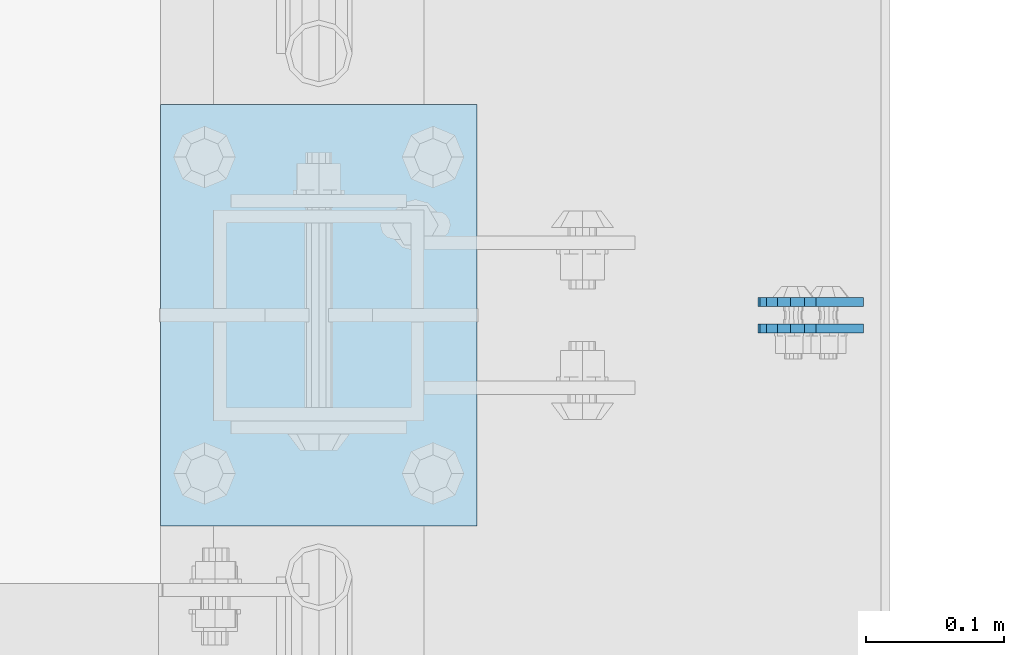
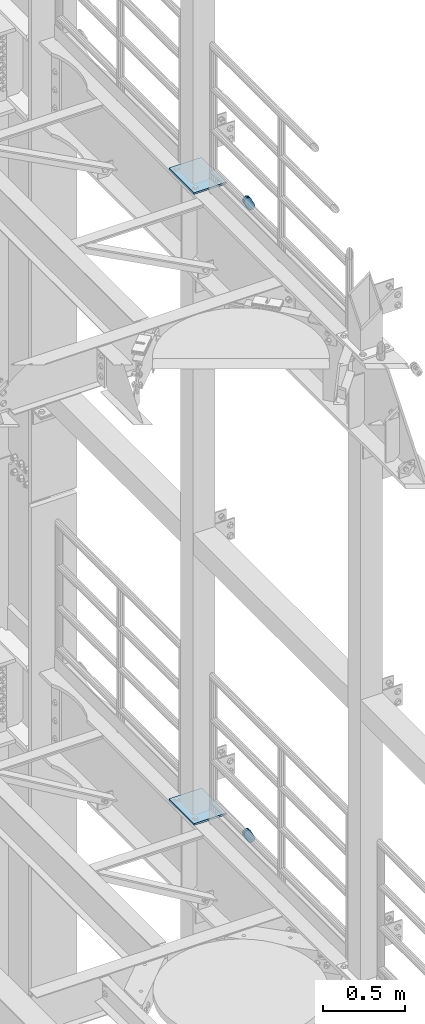
# One storey, part 1681 of 1876: 6 plates, 6 elements without a shape of their own.
"""IFC2X3 building model written with IfcOpenShell, lengths in millimetres."""

from ifc_helpers import new_model, si_unit, frame, origin_with_axes, place, context, subcontext, project, spatial, faceted_brep, material, type_object, element, aggregate, save


model = new_model("IFC2X3")

# Units and contexts
model_context = context("Model", 3, precision=1e-05, world=origin_with_axes())
body_context = subcontext(model_context, "Body", "Model", "MODEL_VIEW")
ifc_project = project(units=[si_unit("LENGTHUNIT", "METRE", prefix="MILLI"), si_unit("AREAUNIT", "SQUARE_METRE"), si_unit("VOLUMEUNIT", "CUBIC_METRE"), si_unit("MASSUNIT", "GRAM", prefix="KILO"), si_unit("TIMEUNIT", "SECOND"), si_unit("PLANEANGLEUNIT", "RADIAN"), si_unit("SOLIDANGLEUNIT", "STERADIAN"), si_unit("THERMODYNAMICTEMPERATUREUNIT", "DEGREE_CELSIUS"), si_unit("LUMINOUSINTENSITYUNIT", "LUMEN")], contexts=[model_context])

# Site, building, storey
site_placement = place(None, origin_with_axes())
site = spatial("IfcSite", under=ifc_project, at=site_placement, CompositionType="ELEMENT")
building_placement = place(site_placement, origin_with_axes())
building = spatial("IfcBuilding", under=site, at=building_placement, Name="Undefined", CompositionType="ELEMENT")
storey_placement = place(building_placement, origin_with_axes())
storey = spatial("IfcBuildingStorey", under=building, at=storey_placement, Name="Undefined", CompositionType="ELEMENT", Elevation=0.0)

# Assembly, plate
assembly_1_placement = place(storey_placement, origin_with_axes())
assembly_1 = element("IfcElementAssembly", 1, at=assembly_1_placement, inside=storey, Name="PLATE", AssemblyPlace="NOTDEFINED", PredefinedType="RIGID_FRAME")
ifc_material = material(Name="STEEL/A36")
plate_type_1 = type_object("IfcPlateType", PredefinedType="NOTDEFINED")
plate_1_placement = place(assembly_1_placement, frame((7974.16265106708, 5578.47500307524, 17725.1776774809), z_axis=(-0.894427191199917, 1.49999996210681e-08, -0.447213595099955), x_axis=(0.447213595099955, -6.99999707257281e-09, -0.894427191199917)))
plate_1 = element("IfcPlate", 2, at=plate_1_placement, type_object=plate_type_1, material=ifc_material, Name="PLATE", context=body_context, shape_type="Brep", body=[
    faceted_brep([(-8.59611645864788e-07, -3.17499999999654, 25.3999987589127), (1.93345873884391, -3.17499999999382, 35.1201580589886), (1.93345873884391, 3.17500000000564, 35.1201580589886), (-8.59611645864788e-07, 3.17500000000382, 25.3999987589132), (7.43948648259902, -3.17499999999109, 43.3605112870105), (7.43948648259902, 3.17500000000928, 43.3605112870105), (15.6798395242777, -3.17499999998654, 48.8665393096448), (15.6798395242777, 3.17500000001382, 48.8665393096448), (25.3999987589095, -3.17499999998199, 50.7999992370592), (25.3999987589095, 3.17500000001837, 50.7999992370592), (82.196130752618, -3.17499999998381, 50.7999992370605), (82.196130752618, 3.17500000001655, 50.7999992370642), (91.9162897887145, -3.17499999997926, 48.8665393918873), (91.9162897887145, 3.1750000000211, 48.8665393918909), (100.156642725027, -3.17499999997472, 43.3605115909359), (100.156642725027, 3.17500000002565, 43.3605115909395), (105.662670525982, -3.17499999997108, 35.1201586546285), (105.662670525986, 3.17500000002929, 35.1201586546358), (107.596130371159, -3.17499999996744, 25.3999996185757), (107.596130371159, 3.17500000003292, 25.3999996185794), (105.662670525981, -3.17499999996471, 15.6798405824902), (105.662670525981, 3.17500000003565, 15.6798405824939), (100.156642725024, -3.17499999996471, 7.43948764618654), (100.156642725025, 3.17500000003565, 7.43948764619017), (91.9162897887127, -3.17499999996562, 1.93345984522784), (91.9162897887127, 3.17500000003474, 1.93345984523148), (82.196130752618, -3.17499999996835, 4.54747350886464e-11), (82.196130752618, 3.1750000000311, 4.91127138957381e-11), (25.399998758905, -3.17499999999018, -8.64019966684282e-12), (25.399998758905, 3.17500000001019, -8.64019966684282e-12), (15.679839921364, -3.17499999999382, 1.9334597629304), (15.679839921364, 3.17500000000655, 1.9334597629304), (7.43948709043525, -3.17499999999654, 7.43948734220839), (7.43948709043525, 3.17500000000382, 7.43948734220885), (1.93345923228208, -3.17499999999654, 15.6798399868012), (1.93345923228208, 3.17500000000291, 15.6798399868012)], [[[0, 1, 2, 3]], [[1, 4, 5, 2]], [[4, 6, 7, 5]], [[6, 8, 9, 7]], [[8, 10, 11, 9]], [[10, 12, 13, 11]], [[12, 14, 15, 13]], [[14, 16, 17, 15]], [[16, 18, 19, 17]], [[18, 20, 21, 19]], [[20, 22, 23, 21]], [[22, 24, 25, 23]], [[24, 26, 27, 25]], [[26, 28, 29, 27]], [[28, 30, 31, 29]], [[30, 32, 33, 31]], [[32, 34, 35, 33]], [[34, 0, 3, 35]], [[5, 7, 9, 11, 13, 15, 17, 19, 21, 23, 25, 27, 29, 31, 33, 35, 3, 2]], [[34, 32, 30, 28, 26, 24, 22, 20, 18, 16, 14, 12, 10, 8, 6, 4, 1, 0]]]),
])
aggregate(assembly_1, [plate_1])

assembly_2_placement = place(storey_placement, origin_with_axes())
assembly_2 = element("IfcElementAssembly", 3, at=assembly_2_placement, inside=storey, Name="PLATE", AssemblyPlace="NOTDEFINED", PredefinedType="RIGID_FRAME")
plate_2_placement = place(assembly_2_placement, frame((7974.16265166367, 5597.53619937992, 17725.1776774809), z_axis=(-0.894427191199917, 1.49999996210681e-08, -0.447213595099955), x_axis=(0.447213595099955, -6.99999707257281e-09, -0.894427191199917)))
plate_2 = element("IfcPlate", 4, at=plate_2_placement, type_object=plate_type_1, material=ifc_material, Name="PLATE", context=body_context, shape_type="Brep", body=[
    faceted_brep([(-8.59611645864788e-07, -3.17499999999654, 25.3999987589127), (1.93345873884391, -3.17499999999382, 35.1201580589886), (1.93345873884391, 3.17500000000564, 35.1201580589886), (-8.59611645864788e-07, 3.17500000000382, 25.3999987589132), (7.43948648259902, -3.17499999999109, 43.3605112870105), (7.43948648259902, 3.17500000000928, 43.3605112870105), (15.6798395242777, -3.17499999998654, 48.8665393096448), (15.6798395242777, 3.17500000001382, 48.8665393096448), (25.3999987589095, -3.17499999998199, 50.7999992370592), (25.3999987589095, 3.17500000001837, 50.7999992370592), (82.196130752618, -3.17499999998381, 50.7999992370605), (82.196130752618, 3.17500000001655, 50.7999992370642), (91.9162897887145, -3.17499999997926, 48.8665393918873), (91.9162897887145, 3.1750000000211, 48.8665393918909), (100.156642725027, -3.17499999997472, 43.3605115909359), (100.156642725027, 3.17500000002565, 43.3605115909395), (105.662670525982, -3.17499999997108, 35.1201586546285), (105.662670525986, 3.17500000002929, 35.1201586546358), (107.596130371159, -3.17499999996744, 25.3999996185757), (107.596130371159, 3.17500000003292, 25.3999996185794), (105.662670525981, -3.17499999996471, 15.6798405824902), (105.662670525981, 3.17500000003565, 15.6798405824939), (100.156642725024, -3.17499999996471, 7.43948764618654), (100.156642725025, 3.17500000003565, 7.43948764619017), (91.9162897887127, -3.17499999996562, 1.93345984522784), (91.9162897887127, 3.17500000003474, 1.93345984523148), (82.196130752618, -3.17499999996835, 4.54747350886464e-11), (82.196130752618, 3.1750000000311, 4.91127138957381e-11), (25.399998758905, -3.17499999999018, -8.64019966684282e-12), (25.399998758905, 3.17500000001019, -8.64019966684282e-12), (15.679839921364, -3.17499999999382, 1.9334597629304), (15.679839921364, 3.17500000000655, 1.9334597629304), (7.43948709043525, -3.17499999999654, 7.43948734220839), (7.43948709043525, 3.17500000000382, 7.43948734220885), (1.93345923228208, -3.17499999999654, 15.6798399868012), (1.93345923228208, 3.17500000000291, 15.6798399868012)], [[[0, 1, 2, 3]], [[1, 4, 5, 2]], [[4, 6, 7, 5]], [[6, 8, 9, 7]], [[8, 10, 11, 9]], [[10, 12, 13, 11]], [[12, 14, 15, 13]], [[14, 16, 17, 15]], [[16, 18, 19, 17]], [[18, 20, 21, 19]], [[20, 22, 23, 21]], [[22, 24, 25, 23]], [[24, 26, 27, 25]], [[26, 28, 29, 27]], [[28, 30, 31, 29]], [[30, 32, 33, 31]], [[32, 34, 35, 33]], [[34, 0, 3, 35]], [[5, 7, 9, 11, 13, 15, 17, 19, 21, 23, 25, 27, 29, 31, 33, 35, 3, 2]], [[34, 32, 30, 28, 26, 24, 22, 20, 18, 16, 14, 12, 10, 8, 6, 4, 1, 0]]]),
])
aggregate(assembly_2, [plate_2])

assembly_3_placement = place(storey_placement, origin_with_axes())
assembly_3 = element("IfcElementAssembly", 5, at=assembly_3_placement, inside=storey, Name="PLATE", AssemblyPlace="NOTDEFINED", PredefinedType="RIGID_FRAME")
plate_3_placement = place(assembly_3_placement, frame((7974.16265106708, 5578.47500307524, 13038.8776774809), z_axis=(-0.894427191199917, 1.49999996210681e-08, -0.447213595099955), x_axis=(0.447213595099955, -6.99999707257281e-09, -0.894427191199917)))
plate_3 = element("IfcPlate", 6, at=plate_3_placement, type_object=plate_type_1, material=ifc_material, Name="PLATE", context=body_context, shape_type="Brep", body=[
    faceted_brep([(-8.59611645864788e-07, -3.17499999999654, 25.3999987589127), (1.93345873884391, -3.17499999999382, 35.1201580589886), (1.93345873884391, 3.17500000000564, 35.1201580589886), (-8.59611645864788e-07, 3.17500000000382, 25.3999987589132), (7.43948648259902, -3.17499999999109, 43.3605112870105), (7.43948648259902, 3.17500000000928, 43.3605112870105), (15.6798395242777, -3.17499999998654, 48.8665393096448), (15.6798395242777, 3.17500000001382, 48.8665393096448), (25.3999987589095, -3.17499999998199, 50.7999992370592), (25.3999987589095, 3.17500000001837, 50.7999992370592), (82.196130752618, -3.17499999998381, 50.7999992370605), (82.196130752618, 3.17500000001655, 50.7999992370642), (91.9162897887145, -3.17499999997926, 48.8665393918873), (91.9162897887145, 3.1750000000211, 48.8665393918909), (100.156642725027, -3.17499999997472, 43.3605115909359), (100.156642725027, 3.17500000002565, 43.3605115909395), (105.662670525982, -3.17499999997108, 35.1201586546285), (105.662670525986, 3.17500000002929, 35.1201586546358), (107.596130371159, -3.17499999996744, 25.3999996185757), (107.596130371159, 3.17500000003292, 25.3999996185794), (105.662670525981, -3.17499999996471, 15.6798405824902), (105.662670525981, 3.17500000003565, 15.6798405824939), (100.156642725024, -3.17499999996471, 7.43948764618654), (100.156642725025, 3.17500000003565, 7.43948764619017), (91.9162897887127, -3.17499999996562, 1.93345984522784), (91.9162897887127, 3.17500000003474, 1.93345984523148), (82.196130752618, -3.17499999996835, 4.54747350886464e-11), (82.196130752618, 3.1750000000311, 4.91127138957381e-11), (25.399998758905, -3.17499999999018, -8.64019966684282e-12), (25.399998758905, 3.17500000001019, -8.64019966684282e-12), (15.679839921364, -3.17499999999382, 1.9334597629304), (15.679839921364, 3.17500000000655, 1.9334597629304), (7.43948709043525, -3.17499999999654, 7.43948734220839), (7.43948709043525, 3.17500000000382, 7.43948734220885), (1.93345923228208, -3.17499999999654, 15.6798399868012), (1.93345923228208, 3.17500000000291, 15.6798399868012)], [[[0, 1, 2, 3]], [[1, 4, 5, 2]], [[4, 6, 7, 5]], [[6, 8, 9, 7]], [[8, 10, 11, 9]], [[10, 12, 13, 11]], [[12, 14, 15, 13]], [[14, 16, 17, 15]], [[16, 18, 19, 17]], [[18, 20, 21, 19]], [[20, 22, 23, 21]], [[22, 24, 25, 23]], [[24, 26, 27, 25]], [[26, 28, 29, 27]], [[28, 30, 31, 29]], [[30, 32, 33, 31]], [[32, 34, 35, 33]], [[34, 0, 3, 35]], [[5, 7, 9, 11, 13, 15, 17, 19, 21, 23, 25, 27, 29, 31, 33, 35, 3, 2]], [[34, 32, 30, 28, 26, 24, 22, 20, 18, 16, 14, 12, 10, 8, 6, 4, 1, 0]]]),
])
aggregate(assembly_3, [plate_3])

assembly_4_placement = place(storey_placement, origin_with_axes())
assembly_4 = element("IfcElementAssembly", 7, at=assembly_4_placement, inside=storey, Name="PLATE", AssemblyPlace="NOTDEFINED", PredefinedType="RIGID_FRAME")
plate_4_placement = place(assembly_4_placement, frame((7974.16265166367, 5597.53619937992, 13038.8776774809), z_axis=(-0.894427191199917, 1.49999996210681e-08, -0.447213595099955), x_axis=(0.447213595099955, -6.99999707257281e-09, -0.894427191199917)))
plate_4 = element("IfcPlate", 8, at=plate_4_placement, type_object=plate_type_1, material=ifc_material, Name="PLATE", context=body_context, shape_type="Brep", body=[
    faceted_brep([(-8.59611645864788e-07, -3.17499999999654, 25.3999987589127), (1.93345873884391, -3.17499999999382, 35.1201580589886), (1.93345873884391, 3.17500000000564, 35.1201580589886), (-8.59611645864788e-07, 3.17500000000382, 25.3999987589132), (7.43948648259902, -3.17499999999109, 43.3605112870105), (7.43948648259902, 3.17500000000928, 43.3605112870105), (15.6798395242777, -3.17499999998654, 48.8665393096448), (15.6798395242777, 3.17500000001382, 48.8665393096448), (25.3999987589095, -3.17499999998199, 50.7999992370592), (25.3999987589095, 3.17500000001837, 50.7999992370592), (82.196130752618, -3.17499999998381, 50.7999992370605), (82.196130752618, 3.17500000001655, 50.7999992370642), (91.9162897887145, -3.17499999997926, 48.8665393918873), (91.9162897887145, 3.1750000000211, 48.8665393918909), (100.156642725027, -3.17499999997472, 43.3605115909359), (100.156642725027, 3.17500000002565, 43.3605115909395), (105.662670525982, -3.17499999997108, 35.1201586546285), (105.662670525986, 3.17500000002929, 35.1201586546358), (107.596130371159, -3.17499999996744, 25.3999996185757), (107.596130371159, 3.17500000003292, 25.3999996185794), (105.662670525981, -3.17499999996471, 15.6798405824902), (105.662670525981, 3.17500000003565, 15.6798405824939), (100.156642725024, -3.17499999996471, 7.43948764618654), (100.156642725025, 3.17500000003565, 7.43948764619017), (91.9162897887127, -3.17499999996562, 1.93345984522784), (91.9162897887127, 3.17500000003474, 1.93345984523148), (82.196130752618, -3.17499999996835, 4.54747350886464e-11), (82.196130752618, 3.1750000000311, 4.91127138957381e-11), (25.399998758905, -3.17499999999018, -8.64019966684282e-12), (25.399998758905, 3.17500000001019, -8.64019966684282e-12), (15.679839921364, -3.17499999999382, 1.9334597629304), (15.679839921364, 3.17500000000655, 1.9334597629304), (7.43948709043525, -3.17499999999654, 7.43948734220839), (7.43948709043525, 3.17500000000382, 7.43948734220885), (1.93345923228208, -3.17499999999654, 15.6798399868012), (1.93345923228208, 3.17500000000291, 15.6798399868012)], [[[0, 1, 2, 3]], [[1, 4, 5, 2]], [[4, 6, 7, 5]], [[6, 8, 9, 7]], [[8, 10, 11, 9]], [[10, 12, 13, 11]], [[12, 14, 15, 13]], [[14, 16, 17, 15]], [[16, 18, 19, 17]], [[18, 20, 21, 19]], [[20, 22, 23, 21]], [[22, 24, 25, 23]], [[24, 26, 27, 25]], [[26, 28, 29, 27]], [[28, 30, 31, 29]], [[30, 32, 33, 31]], [[32, 34, 35, 33]], [[34, 0, 3, 35]], [[5, 7, 9, 11, 13, 15, 17, 19, 21, 23, 25, 27, 29, 31, 33, 35, 3, 2]], [[34, 32, 30, 28, 26, 24, 22, 20, 18, 16, 14, 12, 10, 8, 6, 4, 1, 0]]]),
])
aggregate(assembly_4, [plate_4])

assembly_5_placement = place(storey_placement, origin_with_axes())
assembly_5 = element("IfcElementAssembly", 9, at=assembly_5_placement, inside=storey, Name="BEAM", AssemblyPlace="NOTDEFINED", PredefinedType="RIGID_FRAME")
plate_type_2 = type_object("IfcPlateType", PredefinedType="NOTDEFINED")
plate_5_placement = place(assembly_5_placement, frame((7505.7, 5435.6, 17989.55), z_axis=(0.0, 1.0, 0.0), x_axis=(1.0, 0.0, 0.0)))
plate_5 = element("IfcPlate", 10, at=plate_5_placement, type_object=plate_type_2, material=ifc_material, Name="PLATE", context=body_context, shape_type="Brep", body=[
    faceted_brep([(0.0, -6.35000000000036, 0.0), (0.0, -6.35000000000036, 304.799987792969), (0.0, 6.35000000000036, 304.799987792969), (0.0, 6.35000000000036, 0.0), (228.600006103516, -6.34999999999854, 304.799987792969), (228.600006103516, 6.34999999999854, 304.799987792969), (228.600006103516, -6.34999999999854, 0.0), (228.600006103516, 6.34999999999854, 0.0)], [[[0, 1, 2, 3]], [[1, 4, 5, 2]], [[4, 6, 7, 5]], [[6, 0, 3, 7]], [[5, 7, 3, 2]], [[6, 4, 1, 0]]]),
])
aggregate(assembly_5, [plate_5])

assembly_6_placement = place(storey_placement, origin_with_axes())
assembly_6 = element("IfcElementAssembly", 11, at=assembly_6_placement, inside=storey, Name="BEAM", AssemblyPlace="NOTDEFINED", PredefinedType="RIGID_FRAME")
plate_6_placement = place(assembly_6_placement, frame((7505.7, 5435.6, 13315.95), z_axis=(0.0, 1.0, 0.0), x_axis=(1.0, 0.0, 0.0)))
plate_6 = element("IfcPlate", 12, at=plate_6_placement, type_object=plate_type_2, material=ifc_material, Name="PLATE", context=body_context, shape_type="Brep", body=[
    faceted_brep([(0.0, -6.35000000000036, 0.0), (0.0, -6.35000000000036, 304.799987792969), (0.0, 6.35000000000036, 304.799987792969), (0.0, 6.35000000000036, 0.0), (228.600006103516, -6.34999999999854, 304.799987792969), (228.600006103516, 6.34999999999854, 304.799987792969), (228.600006103516, -6.34999999999854, 0.0), (228.600006103516, 6.34999999999854, 0.0)], [[[0, 1, 2, 3]], [[1, 4, 5, 2]], [[4, 6, 7, 5]], [[6, 0, 3, 7]], [[5, 7, 3, 2]], [[6, 4, 1, 0]]]),
])
aggregate(assembly_6, [plate_6])

save(model, "model.ifc")
